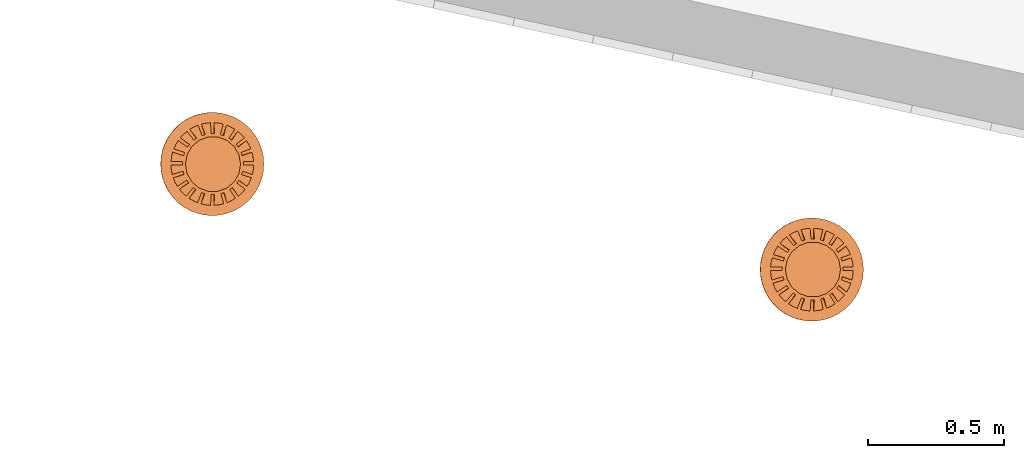
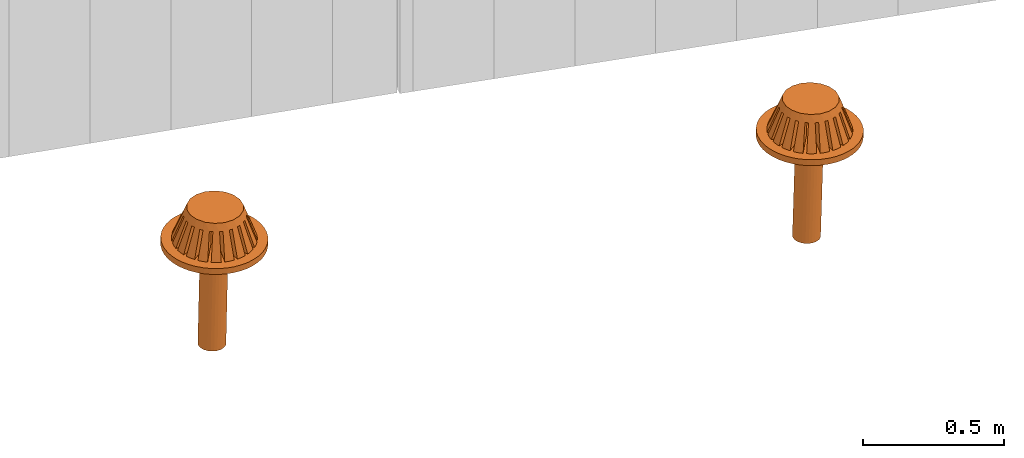
# One storey, part 14 of 18: 2 proxies.
"""IFC2X3 building model written with IfcOpenShell, lengths in centimetres."""

import ifcopenshell
import ifcopenshell.guid

model = None  # the IFC model being written
_history = None  # IfcOwnerHistory: only IFC2X3 demands one
_inside = {}  # id of a spatial element -> (the spatial element, [elements in it])
_under = {}  # id of a project, library or spatial element -> (it, [spatial elements below it])
_declared = {}  # id of a project -> (the project, [libraries it declares])
_typed = {}  # id of a type object -> (the type object, [elements of that type])
_made_of = {}  # id of a material, layer set ... -> (it, [elements and type objects made of it])


def new_model(schema):
    """Start an empty IFC model of exactly this schema.

    Asked for "IFC4X3", IfcOpenShell would pick the latest addendum, in which some entities
    have other attributes; the version numbers below select the first issue.
    IFC2X3 requires an IfcOwnerHistory on every rooted entity: one is made here for all.
    """
    global model, _history
    if schema == "IFC4X3":
        model = ifcopenshell.file(schema_version=(4, 3, 0, 0))
    else:
        model = ifcopenshell.file(schema=schema)
    _inside.clear()
    _under.clear()
    _declared.clear()
    _typed.clear()
    _made_of.clear()
    _history = None
    if model.schema == "IFC2X3":
        org = make("IfcOrganization", Name="unknown")
        user = make(
            "IfcPersonAndOrganization",
            ThePerson=make("IfcPerson", FamilyName="unknown"),
            TheOrganization=org,
        )
        app = make(
            "IfcApplication",
            ApplicationDeveloper=org,
            Version="unknown",
            ApplicationFullName="unknown",
            ApplicationIdentifier="unknown",
        )
        _history = make(
            "IfcOwnerHistory",
            OwningUser=user,
            OwningApplication=app,
            ChangeAction="ADDED",
            CreationDate=0,
        )
    return model


def make(cls, **values):
    """One entity of the class cls with the attributes given. An attribute that is None is left unset."""
    return model.create_entity(
        cls, **{name: value for name, value in values.items() if value is not None}
    )


def entity(cls, *values):
    """Any entity or typed value of the class cls, its attributes in the order of the schema. None: left unset."""
    e = model.create_entity(cls)
    for i, value in enumerate(values):
        if value is not None:
            e[i] = value
    return e


def rooted(cls, **values):
    """An entity with a GlobalId (a new one), such as an element, a storey or a relation."""
    return make(cls, GlobalId=ifcopenshell.guid.new(), OwnerHistory=_history, **values)


def si_unit(unit_type, name, prefix=None):
    """IfcSIUnit, for example si_unit("LENGTHUNIT", "METRE", prefix="MILLI")."""
    return make("IfcSIUnit", UnitType=unit_type, Prefix=prefix, Name=name)


def converted_unit(unit_type, name, factor, base, dimensions=None, offset=None):
    """IfcConversionBasedUnit, such as the inch: factor (a typed value) times the base unit."""
    return make(
        "IfcConversionBasedUnit"
        if offset is None
        else "IfcConversionBasedUnitWithOffset",
        ConversionOffset=offset,
        Dimensions=None
        if dimensions is None
        else entity("IfcDimensionalExponents", *dimensions),
        UnitType=unit_type,
        Name=name,
        ConversionFactor=make(
            "IfcMeasureWithUnit", ValueComponent=factor, UnitComponent=base
        ),
    )


def derived_unit(unit_type, elements):
    """IfcDerivedUnit: a product of units, each with its exponent."""
    return make(
        "IfcDerivedUnit",
        Elements=[
            make("IfcDerivedUnitElement", Unit=unit, Exponent=power)
            for unit, power in elements
        ],
        UnitType=unit_type,
    )


def assignment(units):
    """IfcUnitAssignment: the units of a project."""
    return None if units is None else make("IfcUnitAssignment", Units=units)


def point(xyz):
    """IfcCartesianPoint."""
    return None if xyz is None else make("IfcCartesianPoint", Coordinates=xyz)


def direction(xyz):
    """IfcDirection."""
    return None if xyz is None else make("IfcDirection", DirectionRatios=xyz)


def frame(location, z_axis=None, x_axis=None):
    """IfcAxis2Placement3D, a coordinate frame: its origin and axes. An axis left out is left unset."""
    return make(
        "IfcAxis2Placement3D",
        Location=point(location),
        Axis=direction(z_axis),
        RefDirection=direction(x_axis),
    )


def frame_2d(location, x_axis=None):
    """IfcAxis2Placement2D, a coordinate frame in the plane: its origin and x axis."""
    return make(
        "IfcAxis2Placement2D", Location=point(location), RefDirection=direction(x_axis)
    )


def origin():
    """The frame at (0, 0, 0) with its axes left unset."""
    return frame((0.0, 0.0, 0.0))


def place(relative_to, where):
    """IfcLocalPlacement: puts the frame where relative to a parent placement (None: the world)."""
    return make(
        "IfcLocalPlacement", PlacementRelTo=relative_to, RelativePlacement=where
    )


def context(
    kind, dimensions, precision=None, world=None, true_north=None, identifier=None
):
    """IfcGeometricRepresentationContext, for example the 3D "Model" context."""
    return make(
        "IfcGeometricRepresentationContext",
        ContextIdentifier=identifier,
        ContextType=kind,
        CoordinateSpaceDimension=dimensions,
        Precision=precision,
        WorldCoordinateSystem=world,
        TrueNorth=true_north,
    )


def subcontext(parent, identifier, kind, view, scale=None):
    """IfcGeometricRepresentationSubContext, for example "Body" below "Model"."""
    return make(
        "IfcGeometricRepresentationSubContext",
        ContextIdentifier=identifier,
        ContextType=kind,
        ParentContext=parent,
        TargetScale=scale,
        TargetView=view,
    )


def project(units=None, contexts=None):
    """IfcProject with its units and contexts."""
    return rooted(
        "IfcProject",
        Name="project",
        RepresentationContexts=contexts,
        UnitsInContext=assignment(units),
    )


def spatial(cls, under=None, at=None, **own):
    """A site, building, storey or space (cls), placed at a placement, below another one or the project."""
    s = rooted(cls, ObjectPlacement=at, **own)
    if under is not None:
        _under.setdefault(under.id(), (under, []))[1].append(s)
    return s


def profile(cls, at=None, kind="AREA", **sizes):
    """A parametric profile (cls). Its sizes go by their IFC names, for example OverallWidth=200.0."""
    return make(cls, ProfileType=kind, Position=at, **sizes)


def circle(**sizes):
    """IfcCircleProfileDef."""
    return profile("IfcCircleProfileDef", **sizes)


def extrude(swept, where, along, depth):
    """IfcExtrudedAreaSolid: the profile swept, set in the frame where, extruded along a direction by depth."""
    return make(
        "IfcExtrudedAreaSolid",
        SweptArea=swept,
        Position=where,
        ExtrudedDirection=direction(along),
        Depth=depth,
    )


def faces_of(points, faces, orient=None, outer=None):
    """IfcFace entities. A face is a list of loops; a loop is a list of indices into points, from 0.

    orient and outer hold one flag for each loop. By default every Orientation is true, the
    first loop of a face is its IfcFaceOuterBound and the others are IfcFaceBound.
    """
    made = []
    for i, loops in enumerate(faces):
        bounds = []
        for j, loop in enumerate(loops):
            is_outer = j == 0 if outer is None else outer[i][j]
            bounds.append(
                make(
                    "IfcFaceOuterBound" if is_outer else "IfcFaceBound",
                    Bound=make("IfcPolyLoop", Polygon=[points[k] for k in loop]),
                    Orientation=True if orient is None else orient[i][j],
                )
            )
        made.append(make("IfcFace", Bounds=bounds))
    return made


def faceted_brep(points, faces, orient=None, outer=None, voids=None):
    """IfcFacetedBrep: a solid bounded by flat faces; with voids (closed shells), ...WithVoids."""
    shared = [point(p) for p in points]
    hull = make("IfcClosedShell", CfsFaces=faces_of(shared, faces, orient, outer))
    if voids is None:
        return make("IfcFacetedBrep", Outer=hull)
    return make(
        "IfcFacetedBrepWithVoids",
        Outer=hull,
        Voids=[
            make(cls, CfsFaces=faces_of(shared, fs, o, b)) for cls, fs, o, b in voids
        ],
    )


def shape(context_of_items, identifier, shape_type, items):
    """IfcShapeRepresentation: the items that make up one representation, for example the "Body"."""
    return make(
        "IfcShapeRepresentation",
        ContextOfItems=context_of_items,
        RepresentationIdentifier=identifier,
        RepresentationType=shape_type,
        Items=items,
    )


def source(mapping_origin, context_of_items, identifier, shape_type, items):
    """IfcRepresentationMap: a shape defined once, which mapped items show again and again."""
    return make(
        "IfcRepresentationMap",
        MappingOrigin=mapping_origin,
        MappedRepresentation=shape(context_of_items, identifier, shape_type, items),
    )


def transform(
    local_origin,
    x_axis=None,
    y_axis=None,
    z_axis=None,
    scale=None,
    scale2=None,
    scale3=None,
    uniform=True,
):
    """IfcCartesianTransformationOperator3D, or its non-uniform kind. x_axis, y_axis, z_axis: its Axis1, 2, 3."""
    if uniform:
        return make(
            "IfcCartesianTransformationOperator3D",
            Axis1=direction(x_axis),
            Axis2=direction(y_axis),
            LocalOrigin=point(local_origin),
            Scale=scale,
            Axis3=direction(z_axis),
        )
    return make(
        "IfcCartesianTransformationOperator3DnonUniform",
        Axis1=direction(x_axis),
        Axis2=direction(y_axis),
        LocalOrigin=point(local_origin),
        Scale=scale,
        Axis3=direction(z_axis),
        Scale2=scale2,
        Scale3=scale3,
    )


def mapped(mapping_source, mapping_target):
    """IfcMappedItem: shows the shape of a source again, moved by a transform."""
    return make(
        "IfcMappedItem", MappingSource=mapping_source, MappingTarget=mapping_target
    )


def made_of(thing, what):
    """Note that an element or type object is made of a material, layer set ...; save() writes the relation."""
    if what is not None:
        _made_of.setdefault(what.id(), (what, []))[1].append(thing)
    return thing


def type_object(cls, material=None, **own):
    """A type object (cls), such as IfcWallType, which elements share."""
    return made_of(rooted(cls, **own), material)


def type_shapes(of_type, sources):
    """Give a type object the sources (RepresentationMaps) that its elements show as mapped items."""
    of_type.RepresentationMaps = sources


def element(
    cls,
    number,
    at=None,
    inside=None,
    cuts=None,
    type_object=None,
    material=None,
    context=None,
    identifier="Body",
    shape_type=None,
    held_by="IfcProductDefinitionShape",
    body=None,
    shapes=None,
    **own,
):
    """One element of the class cls, such as IfcWall. Its Tag is "e" and its number.

    at: its placement. inside: the storey or other place that contains it. cuts: it is an
    opening in that element (IfcRelVoidsElement). A single representation is given by context,
    identifier, shape_type and body (its items); several are given by shapes. held_by: the class
    of the entity that holds the representations. save() writes the other relations.
    """
    e = rooted(cls, Tag="e%d" % number, ObjectPlacement=at, **own)
    if body is not None:
        shapes = [shape(context, identifier, shape_type, body)]
    if shapes is not None:
        e.Representation = make(held_by, Representations=shapes)
    if inside is not None:
        _inside.setdefault(inside.id(), (inside, []))[1].append(e)
    if cuts is not None:
        rooted(
            "IfcRelVoidsElement", RelatingBuildingElement=cuts, RelatedOpeningElement=e
        )
    if type_object is not None:
        _typed.setdefault(type_object.id(), (type_object, []))[1].append(e)
    return made_of(e, material)


def aggregate(whole, parts):
    """IfcRelAggregates: a whole, such as a stair, and the parts it consists of."""
    return rooted("IfcRelAggregates", RelatingObject=whole, RelatedObjects=parts)


def save(model, path):
    """Write the relations noted so far, then the file.

    IfcRelAggregates (storeys below a building ...), IfcRelContainedInSpatialStructure (elements
    in a storey), IfcRelDefinesByType, IfcRelAssociatesMaterial and IfcRelDeclares: one each for
    every whole, place, type object, material and project.
    """
    for whole, parts in _under.values():
        aggregate(whole, parts)
    for where, things in _inside.values():
        rooted(
            "IfcRelContainedInSpatialStructure",
            RelatedElements=things,
            RelatingStructure=where,
        )
    for kind, things in _typed.values():
        rooted("IfcRelDefinesByType", RelatedObjects=things, RelatingType=kind)
    for what, things in _made_of.values():
        rooted("IfcRelAssociatesMaterial", RelatedObjects=things, RelatingMaterial=what)
    for by, libraries in _declared.values():
        rooted("IfcRelDeclares", RelatingContext=by, RelatedDefinitions=libraries)
    model.write(path)


model = new_model("IFC2X3")

# Units and contexts
model_context = context("Model", 3, precision=0.001, world=origin(), true_north=direction((6.12303176911189e-17, 1.0)))
body_context = subcontext(model_context, "Body", "Model", "MODEL_VIEW")
ifc_project = project(units=[si_unit("LENGTHUNIT", "METRE", prefix="CENTI"), si_unit("AREAUNIT", "SQUARE_METRE"), si_unit("VOLUMEUNIT", "CUBIC_METRE"), converted_unit("PLANEANGLEUNIT", "DEGREE", entity("IfcRatioMeasure", 0.0174532925199433), si_unit("PLANEANGLEUNIT", "RADIAN"), dimensions=[0, 0, 0, 0, 0, 0, 0]), si_unit("MASSUNIT", "GRAM", prefix="KILO"), derived_unit("MASSDENSITYUNIT", [(si_unit("MASSUNIT", "GRAM", prefix="KILO"), 1), (si_unit("LENGTHUNIT", "METRE"), -3)]), si_unit("TIMEUNIT", "SECOND"), si_unit("FREQUENCYUNIT", "HERTZ"), si_unit("THERMODYNAMICTEMPERATUREUNIT", "DEGREE_CELSIUS"), derived_unit("THERMALTRANSMITTANCEUNIT", [(si_unit("MASSUNIT", "GRAM", prefix="KILO"), 1), (si_unit("THERMODYNAMICTEMPERATUREUNIT", "KELVIN"), -1), (si_unit("TIMEUNIT", "SECOND"), -3)]), derived_unit("VOLUMETRICFLOWRATEUNIT", [(si_unit("LENGTHUNIT", "METRE"), 3), (si_unit("TIMEUNIT", "SECOND"), -1)]), si_unit("ELECTRICCURRENTUNIT", "AMPERE"), si_unit("ELECTRICVOLTAGEUNIT", "VOLT"), si_unit("POWERUNIT", "WATT"), si_unit("FORCEUNIT", "NEWTON", prefix="KILO"), si_unit("ILLUMINANCEUNIT", "LUX"), si_unit("LUMINOUSFLUXUNIT", "LUMEN"), si_unit("LUMINOUSINTENSITYUNIT", "CANDELA"), derived_unit("USERDEFINED", [(si_unit("MASSUNIT", "GRAM", prefix="KILO"), -1), (si_unit("LENGTHUNIT", "METRE"), -2), (si_unit("TIMEUNIT", "SECOND"), 3), (si_unit("LUMINOUSFLUXUNIT", "LUMEN"), 1)]), derived_unit("LINEARVELOCITYUNIT", [(si_unit("LENGTHUNIT", "METRE"), 1), (si_unit("TIMEUNIT", "SECOND"), -1)]), si_unit("PRESSUREUNIT", "PASCAL"), derived_unit("USERDEFINED", [(si_unit("LENGTHUNIT", "METRE"), -2), (si_unit("MASSUNIT", "GRAM", prefix="KILO"), 1), (si_unit("TIMEUNIT", "SECOND"), -2)])], contexts=[model_context])

# Site, building, storey
site_placement = place(None, origin())
site = spatial("IfcSite", under=ifc_project, at=site_placement, CompositionType="ELEMENT")
building_placement = place(site_placement, origin())
building = spatial("IfcBuilding", under=site, at=building_placement, CompositionType="ELEMENT")
storey_placement = place(building_placement, frame((0.0, 0.0, 1422.0)))
storey = spatial("IfcBuildingStorey", under=building, at=storey_placement, CompositionType="ELEMENT", Elevation=1422.0)

# Proxies
building_element_proxy_type = type_object("IfcBuildingElementProxyType", PredefinedType="NOTDEFINED")
shared_shape = source(origin(), body_context, "Body", "SolidModel", [
    extrude(circle(Radius=19.0, at=frame_2d((0.0, -3.06953469142194e-14), x_axis=(1.0, 0.0))), origin(), (0.0, 0.0, 1.0), 2.54),
    extrude(circle(Radius=5.0, at=frame_2d((1.92355843129092e-27, -8.07772287216293e-15), x_axis=(1.0, 0.0))), frame((0.0, 0.0, -42.6697612033445)), (0.0, 0.0, 1.0), 42.6697612033443),
    faceted_brep([(8.15961547140628, 10.4276513842699, 7.78825156071356), (9.33544387057166, 12.0460403344576, 2.53999999999981), (2.87029335855172, 3.14752405658845, 2.53999999999981), (2.87029335855172, 3.14752405658845, 13.0363510851103), (6.98358988267623, 8.80899102593034, 13.0363510851103), (-7.39582595043583, -10.982576953702, 7.78825156071356), (-6.21980036170578, -9.36391659536252, 13.0363510851103), (-1.84284177569415, -3.33954993092504, 13.0363510851103), (-1.84284177569415, -3.33954993092504, 2.53999999999981), (-8.57165434960121, -12.6009659038898, 2.53999999999981), (-8.41404739521033, -10.2233854881115, 7.78839367121062), (-9.59111679899884, -11.8434825346258, 2.53999999999981), (-2.87029335855034, -2.5930626605136, 2.53999999999981), (-2.87029335855034, -2.59306266051361, 13.0363510851103), (-7.23641261771934, -8.60251027145481, 13.0363510851103), (7.12293375046841, 11.1614344595022, 7.78839367121062), (5.94529897297742, 9.54055924284552, 13.0363510851103), (1.84284177569554, 3.8940113269999, 13.0363510851103), (1.84284177569554, 3.8940113269999, 2.53999999999981), (8.30000315425692, 12.7815315060165, 2.53999999999981), (4.61050960133581, 12.4120170303426, 7.78827857144105), (5.22880343434972, 14.3149297813465, 2.53999999999981), (3.99207528530712, 10.5086719170768, 13.0363510851103), (-3.56561994142997, -12.7515222612399, 7.78827857144105), (-2.94718562540128, -10.8481771479742, 13.0363510851103), (-0.634999999999306, -3.73200151378123, 13.0363510851103), (-0.634999999999306, -3.73200151378123, 2.53999999999981), (-4.18391377444389, -14.6544350122438, 2.53999999999981), (-4.7709107140866, -12.3512194983297, 7.78835325421778), (-5.38954749961934, -14.2551877486548, 2.53999999999981), (-4.15203171408524, -10.446505788522, 13.0363510851103), (3.40011682260275, 12.7966174331448, 7.78835325421778), (2.78123782260139, 10.8919037233371, 13.0363510851103), (0.635000000000694, 4.28646290985607, 13.0363510851103), (0.635000000000694, 4.28646290985607, 2.53999999999981), (4.01875360813548, 14.7005856834699, 2.53999999999981), (3.56561994143155, -12.7515222612405, 7.78827857144105), (4.18391377444547, -14.6544350122444, 2.53999999999981), (0.635000000000696, -3.73200151378123, 2.53999999999981), (0.635000000000695, -3.73200151378123, 13.0363510851103), (2.94718562540286, -10.8481771479748, 13.0363510851103), (-4.61050960133415, 12.4120170303418, 7.78827857144105), (-3.99207528530546, 10.508671917076, 13.0363510851103), (-1.84284177569415, 3.89401132699989, 13.0363510851103), (-1.84284177569414, 3.89401132699988, 2.53999999999981), (-5.22880343434807, 14.3149297813457, 2.53999999999981), (-3.40011682260117, 12.7966174331442, 7.78835325421778), (-4.01875360813389, 14.7005856834693, 2.53999999999981), (-0.634999999999306, 4.28646290985609, 2.53999999999981), (-0.634999999999306, 4.28646290985609, 13.0363510851103), (-2.78123782259981, 10.8919037233365, 13.0363510851103), (4.77091071408826, -12.3512194983305, 7.78835325421777), (4.15203171408689, -10.4465057885229, 13.0363510851103), (1.84284177569554, -3.33954993092504, 13.0363510851103), (1.84284177569554, -3.33954993092504, 2.53999999999981), (5.38954749962098, -14.2551877486556, 2.53999999999981), (2.43086019905985, -15.0448834722211, 2.53999999999981), (0.635000000000694, -15.2267650865205, 2.53999999999981), (-7.0271490791317, -13.5231939947521, 2.53999999999981), (2.87029335855171, -2.59306266051359, 2.53999999999981), (12.0835281839743, -9.28686958168313, 2.53999999999981), (10.9158204820288, -10.634964184435, 2.53999999999981), (9.59111679900109, -11.843482534627, 2.53999999999981), (-12.0835281839714, -9.28686958168203, 2.53999999999981), (-10.9091371340833, -10.6418197217289, 2.53999999999981), (3.61678062896316, -1.56561107765742, 2.53999999999981), (14.3750483455808, -5.06118415613312, 2.53999999999981), (13.6893933941843, -6.69761961441146, 2.53999999999981), (12.8148798460614, -8.24842133569207, 2.53999999999981), (-14.3750483455773, -5.06118415613243, 2.53999999999981), (-3.61678062896177, -1.56561107765742, 2.53999999999981), (-12.8148798460584, -8.2484213356909, 2.53999999999981), (-13.6854426476856, -6.70568859528176, 2.53999999999981), (4.00923221181935, -0.357769301962574, 2.53999999999981), (15.2357999831526, -0.357769301962576, 2.53999999999981), (15.091993692444, -2.11880305533537, 2.53999999999981), (14.7465821637106, -3.8465457866775, 2.53999999999981), (-0.634999999999306, -15.2267650865204, 2.53999999999981), (-2.43017839604844, -15.0449936179264, 2.53999999999981), (8.57165434960338, -12.6009659038909, 2.53999999999981), (7.02577035383633, -13.5239103418815, 2.53999999999981), (-15.2357999831488, -0.357769301962569, 2.53999999999981), (-4.00923221181796, -0.357769301962574, 2.53999999999981), (-14.7465821637071, -3.84654578667679, 2.53999999999981), (-15.0914467339494, -2.12269533290175, 2.53999999999981), (14.6045478126464, 4.35485742454993, 2.53999999999981), (15.0066588257202, 2.65665031354838, 2.53999999999981), (15.2126735044702, 0.912230698037424, 2.53999999999981), (4.00923221181935, 0.912230698037425, 2.53999999999981), (-6.80575831032103, 13.6359544521607, 2.53999999999981), (-8.30000315425477, 12.7815315060154, 2.53999999999981), (0.635000000000694, 15.2267650865154, 2.53999999999981), (1.77660370807615, 15.1360919415938, 2.53999999999981), (2.90596513611333, 14.9603798958325, 2.53999999999981), (-15.0074040021538, 2.65243758005144, 2.53999999999981), (-14.6045478126429, 4.35485742454923, 2.53999999999981), (-4.00923221181797, 0.912230698037428, 2.53999999999981), (-15.2126735044665, 0.91223069803743, 2.53999999999981), (12.5663533924978, 8.62231769391866, 2.53999999999981), (13.4643458163018, 7.13925708593345, 2.53999999999981), (14.1911784650638, 5.55590260648399, 2.53999999999981), (3.61678062896317, 2.12007247373227, 2.53999999999981), (-13.467959911725, 7.1324368778196, 2.53999999999981), (-12.5663533924948, 8.62231769391751, 2.53999999999981), (-3.61678062896178, 2.12007247373227, 2.53999999999981), (-14.1911784650603, 5.5559026064833, 2.53999999999981), (10.6372524386057, 10.9135906354124, 2.53999999999981), (11.8047305137619, 9.63877261363989, 2.53999999999981), (-10.6420383482958, 10.9089238604597, 2.53999999999981), (-9.33544387056942, 12.0460403344565, 2.53999999999981), (-2.87029335855033, 3.14752405658845, 2.53999999999981), (-11.804730513759, 9.63877261363881, 2.53999999999981), (6.80772607331836, 13.6349721565766, 2.53999999999981), (-2.34556631288643, 15.0584168713636, 2.53999999999981), (-0.634999999999306, 15.2267650865153, 2.53999999999981), (10.4653622527995, -8.11120321531528, 7.78823305884087), (2.87029335855172, -2.5930626605136, 13.0363510851103), (8.84699094962167, -6.93538763745311, 13.0363510851103), (-10.9481874613201, 7.44665132754965, 7.78823305884087), (-9.32981615814222, 6.27083574968748, 13.0363510851103), (-3.61678062896178, 2.12007247373227, 13.0363510851103), (-10.1842131428712, 8.46139782631736, 7.78842875148637), (-2.87029335855033, 3.14752405658845, 13.0363510851103), (-8.56279262952923, 7.28336686759414, 13.0363510851103), (11.1943624751735, -7.07104654837063, 7.78842875148637), (9.57294196183155, -5.8930155896474, 13.0363510851103), (3.61678062896316, -1.56561107765742, 13.0363510851103), (12.4729292779123, -4.44314820646743, 7.78822254411232), (10.5706129058111, -3.82504814870544, 13.0363510851103), (-12.7024287449743, 3.73682147488353, 7.78822254411232), (-10.8001123728732, 3.11872141712155, 13.0363510851103), (-4.00923221181796, 0.912230698037428, 13.0363510851103), (-12.2858092879303, 4.9368106322387, 7.78845268437236), (-10.3792782066206, 4.31734113244095, 13.0363510851103), (12.8412129865807, -3.22745381243289, 7.78845268437236), (10.934681905271, -2.60798431263514, 13.0363510851103), (4.00923221181934, -0.357769301962574, 13.0363510851103), (13.2358439831053, -0.357769301962576, 7.78821916765944), (11.2356954244486, -0.357769301962575, 13.0363510851103), (-13.2358439831016, -0.35776930196257, 7.78821916765943), (-11.2356954244448, -0.35776930196257, 13.0363510851103), (-4.00923221181795, -0.357769301962571, 13.0363510851103), (-13.209124060714, 0.91223069803743, 7.78846118750995), (-11.2043154943918, 0.912230698037429, 13.0363510851103), (13.2091240607178, 0.912230698037424, 7.78846118750995), (11.2043154943956, 0.912230698037424, 13.0363510851103), (4.00923221181935, 0.912230698037428, 13.0363510851103), (12.7024287449779, 3.73682147488424, 7.78822254411231), (10.8001123728767, 3.11872141712226, 13.0363510851103), (-12.4729292779088, -4.44314820646674, 7.78822254411232), (-10.5706129058076, -3.82504814870476, 13.0363510851103), (-3.61678062896177, -1.56561107765742, 13.0363510851103), (-12.8412129865771, -3.22745381243218, 7.78845268437236), (-10.9346819052674, -2.60798431263443, 13.0363510851103), (12.2858092879338, 4.93681063223938, 7.78845268437236), (10.3792782066241, 4.31734113244163, 13.0363510851103), (3.61678062896317, 2.12007247373227, 13.0363510851103), (10.9481874613231, 7.44665132755081, 7.78823305884087), (9.32981615814522, 6.27083574968865, 13.0363510851103), (-10.4653622527966, -8.11120321531418, 7.78823305884087), (-8.84699094961877, -6.93538763745202, 13.0363510851103), (-11.1943624751705, -7.07104654836945, 7.78842875148637), (-9.57294196182853, -5.89301558964622, 13.0363510851103), (10.1842131428741, 8.46139782631843, 7.78842875148638), (8.56279262953209, 7.2833668675952, 13.0363510851103), (-0.634999999999306, -13.2254069753517, 7.78831335316191), (-0.634999999999306, -11.223440895929, 13.0363510851103), (-0.634999999999306, 13.2254069753467, 7.78831335316191), (-0.634999999999306, 11.223440895924, 13.0363510851103), (0.635000000000694, 13.2254069753468, 7.78831335316191), (0.635000000000694, 11.2234408959241, 13.0363510851103), (0.635000000000693, -13.2254069753518, 7.78831335316191), (0.635000000000693, -11.2234408959292, 13.0363510851103), (7.395825950438, -10.9825769537031, 7.78825156071356), (6.21980036170794, -9.36391659536358, 13.0363510851103), (-8.15961547140403, 10.4276513842687, 7.78825156071356), (-6.98358988267396, 8.80899102592914, 13.0363510851103), (-7.12293375046627, 11.1614344595012, 7.78839367121062), (-5.94529897297529, 9.5405592428445, 13.0363510851103), (8.4140473952126, -10.2233854881127, 7.78839367121062), (7.23641261772162, -8.60251027145605, 13.0363510851103), (-2.59319911382011, 9.70393960356297, 15.8749999999998), (-3.4221327425461, 9.40223243652444, 15.8749999999998), (-5.07999999999809, 8.79881810244738, 15.8749999999998), (-5.7557528855203, 8.23179410543872, 15.8749999999998), (-6.4315057710425, 7.66477010843005, 15.8749999999998), (-7.78301154208691, 6.53072211441273, 15.8749999999998), (-8.22407791336091, 5.76677274985612, 15.8749999999998), (-8.66514428463491, 5.00282338529952, 15.8749999999998), (-9.10621065590892, 4.23887402074291, 15.8749999999998), (-9.54727702718292, 3.4749246561863, 15.8749999999998), (-9.70045777038672, 2.60619349213911, 15.8749999999998), (-9.85363851359051, 1.73746232809191, 15.8749999999998), (-10.0068192567943, 0.868731164044709, 15.8749999999998), (-10.1599999999981, 0.0, 15.8749999999998), (-9.85363851359053, -1.73746232809688, 15.8749999999998), (-9.70045777038674, -2.60619349214408, 15.8749999999998), (-9.54727702718295, -3.47492465619127, 15.8749999999998), (-8.66514428463495, -5.0028233853045, 15.8749999999998), (-8.22407791336095, -5.76677274986111, 15.8749999999998), (-7.78301154208695, -6.53072211441772, 15.8749999999998), (-6.43150577104255, -7.66477010843505, 15.8749999999998), (-5.75575288552035, -8.23179410544372, 15.8749999999998), (-5.07999999999815, -8.79881810245239, 15.8749999999998), (-3.42213274254616, -9.40223243652946, 15.8749999999998), (-2.59319911382017, -9.70393960356799, 15.8749999999998), (-1.76426548509418, -10.0056467706065, 15.8749999999998), (-0.88213274254617, -10.0056467706065, 15.8749999999998), (0.0, -10.0056467706065, 15.8749999999998), (0.882132742549835, -10.0056467706065, 15.8749999999998), (1.76426548509784, -10.0056467706065, 15.8749999999998), (2.59319911382384, -9.70393960356802, 15.8749999999998), (3.42213274254983, -9.40223243652949, 15.8749999999998), (5.08000000000183, -8.79881810245243, 15.8749999999998), (5.75575288552403, -8.23179410544377, 15.8749999999998), (6.43150577104623, -7.66477010843511, 15.8749999999998), (7.78301154209065, -6.53072211441779, 15.8749999999998), (8.22407791336465, -5.76677274986118, 15.8749999999998), (8.66514428463866, -5.00282338530458, 15.8749999999998), (9.54727702718667, -3.47492465619137, 15.8749999999998), (9.70045777039047, -2.60619349214417, 15.8749999999998), (9.85363851359427, -1.73746232809697, 15.8749999999998), (10.1600000000019, 0.0, 15.8749999999998), (10.0068192567981, 0.86873116404468, 15.8749999999998), (9.85363851359429, 1.73746232809188, 15.8749999999998), (9.70045777039049, 2.60619349213907, 15.8749999999998), (9.5472770271867, 3.47492465618627, 15.8749999999998), (9.1062106559127, 4.23887402074288, 15.8749999999998), (8.6651442846387, 5.00282338529949, 15.8749999999998), (8.2240779133647, 5.7667727498561, 15.8749999999998), (7.78301154209069, 6.53072211441271, 15.8749999999998), (6.43150577104629, 7.66477010843004, 15.8749999999998), (5.75575288552409, 8.2317941054387, 15.8749999999998), (5.08000000000188, 8.79881810244737, 15.8749999999998), (3.42213274254989, 9.40223243652443, 15.8749999999998), (2.5931991138239, 9.70393960356297, 15.8749999999998), (1.7642654850979, 10.0056467706015, 15.8749999999998), (0.8821327425499, 10.0056467706015, 15.8749999999998), (0.0, 10.0056467706015, 15.8749999999998), (-0.882132742546106, 10.0056467706015, 15.8749999999998), (-1.76426548509411, 10.0056467706015, 15.8749999999998), (10.7698531709191, -3.22166311417828, 13.0363510851103), (11.2399663130641, -0.178907310034193, 13.0363510851103), (11.2413900628169, 0.0, 13.0363510851103), (3.5552857379653, -10.6643702986086, 13.0363510851103), (9.22470145788588, -6.42446367857287, 13.0363510851103), (6.73886873551225, -8.99758293709833, 13.0363510851103), (-6.73886873550998, -8.99758293709723, 13.0363510851103), (0.0, -11.2413900628176, 13.0363510851103), (-3.55528573796362, -10.6643702986079, 13.0363510851103), (-10.7698531709156, -3.22166311417766, 13.0363510851103), (-11.2399663130604, -0.178907310034141, 13.0363510851103), (-11.2413900628132, 0.0, 13.0363510851103), (-9.22470145788288, -6.42446367857179, 13.0363510851103), (-8.96061756372554, 6.78794397597258, 13.0363510851103), (-10.6066403085603, 3.72398065369879, 13.0363510851103), (-11.2321175965086, 0.456491886581969, 13.0363510851103), (-3.39207300463341, 10.7174013303379, 13.0363510851103), (-6.47478492109452, 9.18945105922292, 13.0363510851103), (8.96061756372843, 6.78794397597374, 13.0363510851103), (3.39207300463496, 10.7174013303386, 13.0363510851103), (0.0, 11.2413900628125, 13.0363510851103), (10.6066403085638, 3.72398065369954, 13.0363510851103), (11.2321175965123, 0.45649188658195, 13.0363510851103), (6.47478492109666, 9.18945105922407, 13.0363510851103)], [[[0, 1, 2, 3, 4]], [[5, 6, 7, 8, 9]], [[10, 11, 12, 13, 14]], [[15, 16, 17, 18, 19]], [[20, 21, 18, 17, 22]], [[23, 24, 25, 26, 27]], [[28, 29, 8, 7, 30]], [[31, 32, 33, 34, 35]], [[36, 37, 38, 39, 40]], [[41, 42, 43, 44, 45]], [[46, 47, 48, 49, 50]], [[51, 52, 53, 54, 55]], [[38, 37, 56, 57]], [[9, 8, 29, 58]], [[59, 60, 61, 62]], [[63, 12, 11, 64]], [[65, 66, 67, 68]], [[69, 70, 71, 72]], [[73, 74, 75, 76]], [[27, 26, 77, 78]], [[54, 79, 80, 55]], [[81, 82, 83, 84]], [[85, 86, 87, 88]], [[89, 45, 44, 90]], [[91, 92, 93, 35, 34]], [[94, 95, 96, 97]], [[98, 99, 100, 101]], [[102, 103, 104, 105]], [[1, 106, 107, 2]], [[108, 109, 110, 111]], [[21, 112, 19, 18]], [[113, 114, 48, 47]], [[115, 60, 59, 116, 117]], [[118, 119, 120, 104, 103]], [[121, 111, 110, 122, 123]], [[124, 125, 126, 65, 68]], [[127, 66, 65, 126, 128]], [[129, 130, 131, 96, 95]], [[132, 105, 104, 120, 133]], [[134, 135, 136, 73, 76]], [[137, 74, 73, 136, 138]], [[139, 140, 141, 82, 81]], [[142, 97, 96, 131, 143]], [[144, 145, 146, 88, 87]], [[147, 85, 88, 146, 148]], [[149, 150, 151, 70, 69]], [[152, 83, 82, 141, 153]], [[154, 155, 156, 101, 100]], [[157, 98, 101, 156, 158]], [[159, 160, 13, 12, 63]], [[161, 71, 70, 151, 162]], [[163, 164, 3, 2, 107]], [[165, 77, 26, 25, 166]], [[167, 168, 49, 48, 114]], [[169, 91, 34, 33, 170]], [[171, 172, 39, 38, 57]], [[173, 79, 54, 53, 174]], [[175, 176, 122, 110, 109]], [[177, 90, 44, 43, 178]], [[179, 180, 116, 59, 62]], [[181, 182, 183, 184, 185, 186, 187, 188, 189, 190, 191, 192, 193, 194, 195, 196, 197, 198, 199, 200, 201, 202, 203, 204, 205, 206, 207, 208, 209, 210, 211, 212, 213, 214, 215, 216, 217, 218, 219, 220, 221, 222, 223, 224, 225, 226, 227, 228, 229, 230, 231, 232, 233, 234, 235, 236, 237, 238, 239, 240]], [[220, 241, 135]], [[241, 220, 219]], [[219, 218, 128]], [[219, 128, 241]], [[216, 117, 217]], [[127, 128, 125]], [[222, 138, 242]], [[242, 243, 222]], [[124, 127, 125]], [[138, 135, 137]], [[138, 222, 221]], [[135, 134, 137]], [[213, 174, 214]], [[211, 210, 40]], [[213, 212, 52]], [[40, 210, 172]], [[244, 212, 211]], [[209, 208, 172, 210]], [[166, 208, 207, 206]], [[216, 180, 117]], [[245, 217, 117]], [[246, 215, 214]], [[180, 215, 246]], [[213, 52, 174]], [[115, 117, 180]], [[174, 52, 173]], [[125, 218, 217]], [[36, 40, 172]], [[137, 134, 75]], [[60, 115, 61]], [[124, 67, 127]], [[61, 115, 179]], [[76, 75, 134]], [[75, 74, 137]], [[127, 67, 66]], [[68, 67, 124]], [[52, 51, 173]], [[80, 173, 51]], [[56, 36, 171]], [[171, 36, 172]], [[56, 171, 57]], [[173, 80, 79]], [[55, 80, 51]], [[36, 56, 37]], [[179, 62, 61]], [[179, 115, 180]], [[204, 203, 30]], [[6, 202, 247]], [[14, 201, 200]], [[14, 200, 160]], [[52, 212, 244]], [[201, 247, 202]], [[206, 24, 166]], [[248, 208, 166]], [[23, 166, 24]], [[30, 249, 204]], [[205, 204, 249]], [[5, 30, 6]], [[203, 6, 30]], [[250, 196, 153]], [[172, 208, 248]], [[138, 221, 135]], [[200, 199, 160]], [[198, 162, 199]], [[128, 218, 125]], [[150, 197, 250]], [[195, 194, 140]], [[150, 162, 198]], [[150, 198, 197]], [[149, 162, 150]], [[197, 196, 250]], [[139, 152, 153]], [[244, 211, 40]], [[153, 195, 140]], [[194, 251, 140]], [[139, 153, 140]], [[194, 252, 251]], [[14, 160, 159]], [[6, 203, 202]], [[166, 23, 165]], [[78, 165, 23]], [[135, 221, 220]], [[5, 28, 30]], [[11, 10, 64]], [[28, 5, 58]], [[247, 201, 14]], [[125, 217, 245]], [[165, 78, 77]], [[23, 27, 78]], [[160, 199, 253]], [[29, 28, 58]], [[5, 9, 58]], [[246, 214, 174]], [[64, 159, 63]], [[159, 64, 10]], [[153, 196, 195]], [[162, 149, 161]], [[152, 139, 84]], [[72, 161, 149]], [[205, 249, 24]], [[10, 14, 159]], [[152, 84, 83]], [[71, 161, 72]], [[72, 149, 69]], [[24, 206, 205]], [[139, 81, 84]], [[199, 162, 253]], [[180, 216, 215]], [[191, 190, 130, 192]], [[188, 133, 190, 189]], [[119, 187, 254]], [[118, 133, 119]], [[187, 186, 254]], [[255, 190, 133]], [[252, 194, 256]], [[130, 143, 192]], [[256, 194, 193]], [[129, 143, 130]], [[142, 143, 129]], [[130, 190, 255]], [[183, 178, 184]], [[181, 240, 50]], [[182, 181, 257]], [[238, 168, 240, 239]], [[237, 236, 170, 238]], [[167, 50, 168]], [[240, 168, 50]], [[176, 185, 184]], [[123, 186, 185]], [[175, 123, 176]], [[183, 42, 178]], [[258, 184, 178]], [[41, 178, 42]], [[257, 42, 182]], [[186, 123, 254]], [[132, 133, 118]], [[118, 102, 132]], [[111, 121, 108]], [[108, 121, 175]], [[129, 95, 94]], [[97, 142, 94]], [[132, 102, 105]], [[118, 103, 102]], [[94, 142, 129]], [[175, 121, 123]], [[177, 178, 41]], [[41, 89, 177]], [[113, 46, 167]], [[167, 46, 50]], [[113, 167, 114]], [[177, 89, 90]], [[45, 89, 41]], [[46, 113, 47]], [[175, 109, 108]], [[22, 234, 233]], [[231, 164, 4]], [[164, 231, 230]], [[164, 230, 259]], [[42, 183, 182]], [[231, 4, 232]], [[260, 235, 234]], [[32, 170, 236]], [[32, 236, 235]], [[169, 170, 32]], [[233, 16, 22]], [[235, 260, 32]], [[168, 238, 261]], [[20, 22, 16]], [[232, 16, 233]], [[164, 0, 4]], [[170, 261, 238]], [[228, 155, 158]], [[259, 230, 229]], [[157, 158, 155]], [[143, 193, 192]], [[262, 226, 148]], [[223, 222, 263]], [[226, 262, 155]], [[226, 155, 228, 227]], [[259, 229, 158]], [[148, 226, 225, 224]], [[176, 184, 258]], [[145, 147, 148]], [[223, 263, 145]], [[222, 243, 263]], [[144, 147, 145]], [[133, 188, 119]], [[157, 155, 154]], [[31, 92, 169]], [[31, 169, 32]], [[145, 224, 223]], [[257, 181, 50]], [[20, 15, 112]], [[16, 15, 20]], [[15, 19, 112]], [[31, 93, 92]], [[92, 91, 169]], [[35, 93, 31]], [[20, 112, 21]], [[0, 163, 106]], [[232, 4, 264]], [[106, 163, 107]], [[0, 106, 1]], [[148, 224, 145]], [[260, 234, 22]], [[123, 185, 176]], [[157, 154, 99]], [[16, 232, 264]], [[256, 193, 143]], [[99, 98, 157]], [[154, 100, 99]], [[147, 86, 85]], [[147, 144, 86]], [[119, 188, 187]], [[144, 87, 86]], [[158, 229, 228]], [[164, 163, 0]], [[156, 155, 262, 148, 146, 145, 263, 243, 242, 138, 136, 135, 241, 128, 126, 125, 245, 117, 116, 180, 246, 174, 53, 52, 244, 40, 39, 172, 248, 166, 25, 24, 249, 30, 7, 6, 247, 14, 13, 160, 253, 162, 151, 150, 250, 153, 141, 140, 251, 252, 256, 143, 131, 130, 255, 133, 120, 119, 254, 123, 122, 176, 258, 178, 43, 42, 257, 50, 49, 168, 261, 170, 33, 32, 260, 22, 17, 16, 264, 4, 3, 164, 259, 158]]]),
])
type_shapes(building_element_proxy_type, [shared_shape])
for number, where, z_axis, x_axis in (
    (1, (7751.92124070577, 201.730823081866, -386.690497785466), (0.0309018747124168, 0.00226969269058984, 0.999519846043263), (0.999522423029748, -7.01712707981833e-05, -0.0309017950406551)),
    (2, (7531.15024099773, 240.629274083275, -379.759485049555), (0.0195016871564809, -0.00441862671258542, 0.999800059980007), (0.999809824015573, 8.61870665206099e-05, -0.0195014967050946)),
):
    element("IfcBuildingElementProxy", number, at=place(storey_placement, frame(where, z_axis=z_axis, x_axis=x_axis)), inside=storey, type_object=building_element_proxy_type, context=body_context, shape_type="MappedRepresentation", body=[
        mapped(shared_shape, transform((0.0, 0.0, 0.0), scale=1.0)),
    ])

save(model, "model.ifc")
